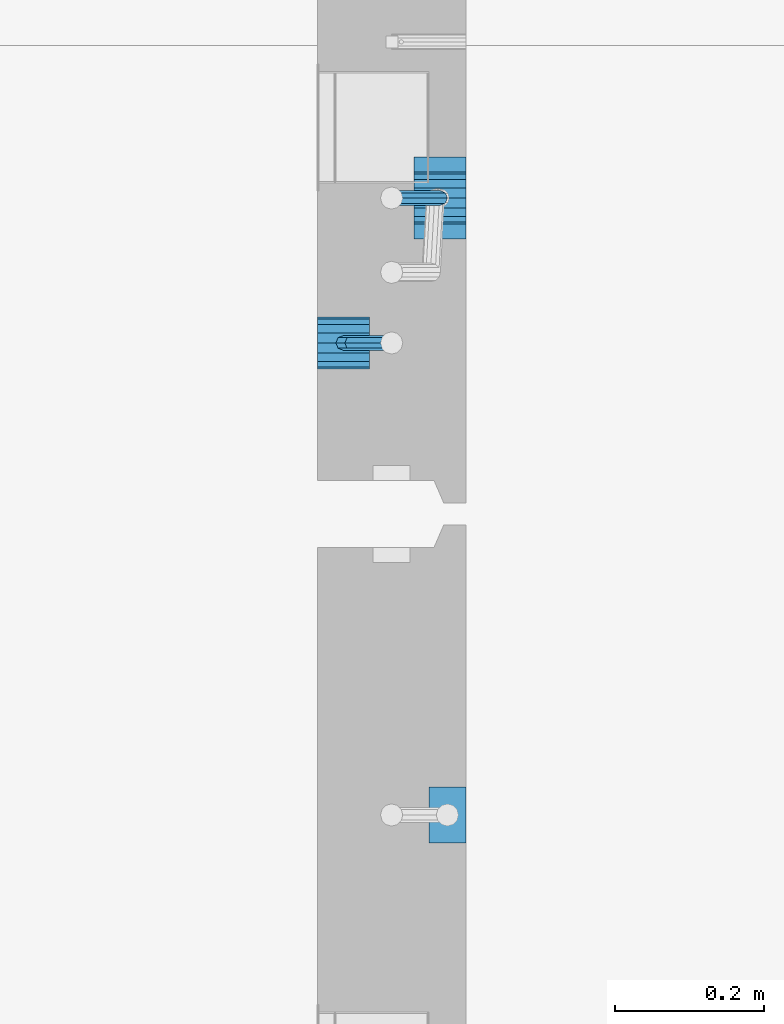
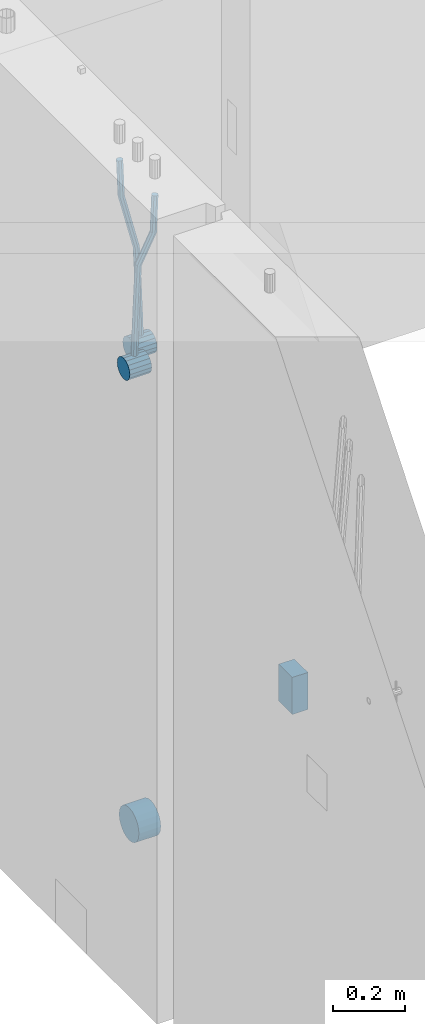
# One storey, part 148 of 349: 6 beams, 2 elements without a shape of their own.
"""IFC2X3 building model written with IfcOpenShell, lengths in millimetres."""

from ifc_helpers import new_model, si_unit, frame, origin_with_axes, place, context, subcontext, project, spatial, faceted_brep, material, type_object, element, aggregate, save


model = new_model("IFC2X3")

# Units and contexts
model_context = context("Model", 3, precision=1e-05, world=origin_with_axes())
body_context = subcontext(model_context, "Body", "Model", "MODEL_VIEW")
ifc_project = project(units=[si_unit("LENGTHUNIT", "METRE", prefix="MILLI"), si_unit("AREAUNIT", "SQUARE_METRE"), si_unit("VOLUMEUNIT", "CUBIC_METRE"), si_unit("MASSUNIT", "GRAM", prefix="KILO"), si_unit("TIMEUNIT", "SECOND"), si_unit("PLANEANGLEUNIT", "RADIAN"), si_unit("SOLIDANGLEUNIT", "STERADIAN"), si_unit("THERMODYNAMICTEMPERATUREUNIT", "DEGREE_CELSIUS"), si_unit("LUMINOUSINTENSITYUNIT", "LUMEN")], contexts=[model_context])

# Site, building, storey
site_placement = place(None, origin_with_axes())
site = spatial("IfcSite", under=ifc_project, at=site_placement, CompositionType="ELEMENT")
building_placement = place(site_placement, origin_with_axes())
building = spatial("IfcBuilding", under=site, at=building_placement, CompositionType="ELEMENT")
storey_placement = place(building_placement, origin_with_axes())
storey = spatial("IfcBuildingStorey", under=building, at=storey_placement, Name="4", CompositionType="ELEMENT", Elevation=0.0)

# Assembly, beams
assembly_1_placement = place(storey_placement, origin_with_axes())
assembly_1 = element("IfcElementAssembly", 1, at=assembly_1_placement, inside=storey, AssemblyPlace="NOTDEFINED", PredefinedType="REINFORCEMENT_UNIT")
ifc_material = material()
beam_type_1 = type_object("IfcBeamType", Name="D20", PredefinedType="NOTDEFINED")
beam_1_placement = place(assembly_1_placement, frame((21875.0000022791, 12925.0000000039, 92795.0), z_axis=(-0.999642804636942, -0.000205726999925762, -0.0267249099902983), x_axis=(-0.0267249099948371, 4.30000201934385e-08, 0.999642825806181)))
beam_1 = element("IfcBeam", 2, at=beam_1_placement, type_object=beam_type_1, material=ifc_material, Name="JM20", ObjectType="D20", context=body_context, shape_type="Brep", body=[
    faceted_brep([(0.0, -10.0, 0.0), (-4.19531716033816e-08, -7.07106781186667, -7.07106781187031), (60.4266690400545, -7.0710677960451, -7.07106780570757), (60.4266690441291, -9.99999998418934, 6.15546014159918e-09), (0.0, 0.0, -10.0), (60.426669036824, 1.58106558956206e-08, -9.99999999384454), (4.196772351861e-08, 7.07106781186303, -7.07106781186667), (60.4266690363438, 7.07106782768096, -7.07106780570757), (0.0, 10.0, 0.0), (60.4266690388904, 10.0000000158179, 6.15182216279209e-09), (4.196772351861e-08, 7.07106781185939, 7.07106781185939), (60.4266690429649, 7.07106782768096, 7.07106781802577), (0.0, 0.0, 10.0), (60.4266690461809, 1.58179318532348e-08, 10.0000000061555), (-4.19531716033816e-08, -7.07106781187031, 7.07106781185939), (60.4266690466611, -7.07106779605238, 7.07106781802213), (61.0378400410118, -7.07106779588503, -7.07106780564936), (60.991799419251, -9.99999998403655, 6.21366780251265e-09), (61.0569027789461, 1.5985278878361e-08, -9.99999999378269), (61.0378209396877, 7.07106782784831, -7.07106780564936), (60.9917724058905, 10.0000000159635, 6.21366780251265e-09), (60.9457317841297, 7.07106782781193, 7.0710678180767), (60.9266690461809, 1.59488990902901e-08, 10.0000000062028), (60.9457508854539, -7.07106779591413, 7.0710678180767), (61.6489592143771, -7.07106614513759, -7.06310863441468), (61.5568818710308, -9.9999984576425, 0.00735959856683621), (61.6870830769039, 1.71821739058942e-06, -9.99179257185824), (61.6489210170112, 7.07106947854481, -7.06310888312146), (61.556827851804, 10.0000015422847, 0.00735924683976918), (61.4647505084577, 7.07106922979438, 7.07782747982128), (61.4266266459163, 1.36643211590126e-06, 10.0065114172685), (61.464788705809, -7.07106639389531, 7.07782772852806), (176.543135720174, -7.07075579406956, -5.56673531796696), (176.451058376813, -9.99968810657447, 1.50373291501455), (176.581259582701, 0.000312069292704109, -8.49541925541052), (176.543097522794, 7.07137982961285, -5.56673556667374), (176.451004357587, 10.00031189336, 1.50373256329476), (176.35892701424, 7.07137958085514, 8.57420079627263), (176.320803151699, 0.000311717507429421, 11.5028847337162), (176.358965211621, -7.07075604281999, 8.57420104497578), (177.098753836006, -7.07075429323595, -5.55949898843028), (176.98362511232, -9.99968666800123, 1.510669025065), (177.146421932586, 0.000313595905026887, -8.48805862247536), (177.098706077581, 7.07138133041735, -5.55949936166144), (176.983557571715, 10.0003133318824, 1.51066849724157), (176.868428848029, 7.07138095712435, 8.58083651073321), (176.820760751449, 0.000313067976094317, 11.5093961447819), (176.868476606425, -7.07075466652896, 8.58083688396073), (177.654312950661, -7.07075204110879, -5.54863964998367), (177.516135294456, -9.99968450931192, 1.52107783331303), (177.711524267797, 0.000315886711177882, -8.47701274570863), (177.654255632195, 7.07138358250813, -5.54864021007961), (177.516054233929, 10.0003154905207, 1.5210770412159), (177.377876577739, 7.0713830223176, 8.59079452451624), (177.320665260588, 0.000315094497636892, 11.5191676202448), (177.377933896176, -7.07075260129932, 8.59079508461218), (298.592214475648, -7.07025824167067, -3.18470470795364), (298.454036904819, -9.99919071054683, 3.88501277673276), (298.649425586758, 0.000809686429420253, -6.11307780703646), (298.592156745173, 7.07187738194261, -3.18470527475802), (298.453955261604, 10.0008092892858, 3.88501197515143), (298.315777690761, 7.07187682041331, 10.9547294598378), (298.258566579665, 0.000808892309578368, 13.883102558917), (298.31583542125, -7.07025880319998, 10.9547300266422), (300.829882012156, -7.07024910539985, -3.14096572775816), (299.972022738802, -9.99918451269514, 3.91468436611831), (301.18507173346, 0.000820039333120803, -6.0635143331092), (300.829526581147, 7.07188651699835, -3.14097211362241), (299.971520083447, 10.0008154854204, 3.91467533514515), (299.113660810108, 7.07188007812692, 10.9703254290253), (298.758471088819, 0.000810933392131119, 13.8928740343799), (299.114016241103, -7.07025554427128, 10.9703318148859), (303.012825988379, -7.0701468967527, -2.64717965084128), (301.452885279024, -9.99911517653163, 4.24965828764471), (303.65870706641, 0.000935858577577164, -5.50397331873319), (303.012180137302, 7.07198871204673, -2.64725173027909), (301.451971907663, 10.0008848023517, 4.24955635192964), (299.892031198324, 7.07191652257279, 11.1463942904193), (299.246150120278, 0.000833767242511385, 14.0031879583075), (299.892677049385, -7.07021908622846, 11.1464663698534), (490.480206458145, -7.06136939830685, 39.7582981627347), (488.920265748791, -9.9903376780876, 46.6551361012243), (491.126087536177, 0.00971335702342913, 36.9015044948464), (490.479560607055, 7.0807662104944, 39.7582260832969), (488.91935237743, 10.0096623007976, 46.6550341655056), (487.359411668076, 7.08069402101864, 53.5518721039953), (486.713530590045, 0.00961126568654436, 56.4086657718872), (487.360057519167, -7.06144158778261, 53.5519441834331), (491.222094319732, -7.06133466202664, 39.9261146072568), (490.367102775039, -9.9902699350514, 46.9824133868096), (491.613766567636, 0.0097361908719904, 37.0118184187741), (491.312683227967, 7.08080521851844, 39.9466800038063), (490.495214837676, 10.0097360849959, 47.0114972495248), (489.640223292983, 7.08080081197113, 54.0677960290814), (489.248551045079, 0.00972995907250152, 56.9820922175604), (489.549634384748, -7.06133906857212, 54.0472306325282), (491.98259360576, -7.07125184727738, 39.9362361015701), (491.850235984879, -10.009610527557, 47.0021524248696), (492.113679795017, 0.00321714190249622, 37.0184717700395), (492.166706040836, 7.06966845271199, 39.958046203883), (492.110610287549, 9.988670745126, 47.0329965673554), (491.978252666668, 7.05031206484455, 54.0989128906476), (491.847166477397, -0.0241569243353297, 57.0166772221819), (491.794140231592, -7.09060823514483, 54.077102788342), (512.839684553823, -7.34323584322192, 40.2138233804726), (512.707326932941, -10.2815945235034, 47.2797397037684), (512.970770743079, -0.268766854042042, 37.296059048942), (513.023796988884, 6.79768445676746, 40.2356334827819), (512.967701235597, 9.71668674918146, 47.3105838462543), (512.83534361473, 6.77832806890183, 54.3765001695538), (512.704257425459, -0.296140920279868, 57.2942645010808), (512.651231179654, -7.36259223108937, 54.3546900672372), (513.475042066755, -7.35152113457298, 40.2222793613946), (513.367413171509, -10.2902022863618, 47.2885247996019), (513.548971693657, -0.276306803183616, 37.3037543324754), (513.545895079456, 6.79087610917486, 40.2425820926655), (513.467614462992, 9.71016770021379, 47.3172371975234), (513.359985567746, 6.77148654842495, 54.3834826357306), (513.286055940844, -0.303727782968053, 57.3020076646499), (513.289132555044, -7.37091069532653, 54.3631799044524), (514.110453382629, -7.34964673829199, 40.2305416874733), (514.027555144421, -10.2882337755309, 47.2971163788461), (514.127221878356, -0.274611275939606, 37.3112548247955), (514.06803787424, 6.7924127919523, 40.249334442502), (513.967570557215, 9.71165861202826, 47.3236933478729), (513.884672319007, 6.77307157479117, 54.3902680392421), (513.867903823266, -0.301963887563034, 57.3095549019235), (513.927087827382, -7.36898795545494, 54.3714752842207), (614.131240716772, -7.05138387012084, 41.5279197320488), (614.048342478563, -9.98997090735793, 48.5944944234179), (614.148009212484, 0.0236515922315448, 38.6086328693636), (614.088825208368, 7.09067566012527, 41.5467124870702), (613.988357891343, 10.0099214802012, 48.6210713924484), (613.905459653135, 7.07133444296232, 55.6876460838175), (613.888691157408, -0.00370101939006418, 58.606932946499), (613.947875161524, -7.07072508728379, 55.6688533287888)], [[[0, 1, 2, 3]], [[1, 4, 5, 2]], [[4, 6, 7, 5]], [[6, 8, 9, 7]], [[8, 10, 11, 9]], [[10, 12, 13, 11]], [[12, 14, 15, 13]], [[14, 0, 3, 15]], [[14, 12, 10, 8, 6, 4, 1, 0]], [[3, 2, 16, 17]], [[2, 5, 18, 16]], [[5, 7, 19, 18]], [[7, 9, 20, 19]], [[9, 11, 21, 20]], [[11, 13, 22, 21]], [[13, 15, 23, 22]], [[15, 3, 17, 23]], [[17, 16, 24, 25]], [[16, 18, 26, 24]], [[18, 19, 27, 26]], [[19, 20, 28, 27]], [[20, 21, 29, 28]], [[21, 22, 30, 29]], [[22, 23, 31, 30]], [[23, 17, 25, 31]], [[25, 24, 32, 33]], [[24, 26, 34, 32]], [[26, 27, 35, 34]], [[27, 28, 36, 35]], [[28, 29, 37, 36]], [[29, 30, 38, 37]], [[30, 31, 39, 38]], [[31, 25, 33, 39]], [[33, 32, 40, 41]], [[32, 34, 42, 40]], [[34, 35, 43, 42]], [[35, 36, 44, 43]], [[36, 37, 45, 44]], [[37, 38, 46, 45]], [[38, 39, 47, 46]], [[39, 33, 41, 47]], [[41, 40, 48, 49]], [[40, 42, 50, 48]], [[42, 43, 51, 50]], [[43, 44, 52, 51]], [[44, 45, 53, 52]], [[45, 46, 54, 53]], [[46, 47, 55, 54]], [[47, 41, 49, 55]], [[49, 48, 56, 57]], [[48, 50, 58, 56]], [[50, 51, 59, 58]], [[51, 52, 60, 59]], [[52, 53, 61, 60]], [[53, 54, 62, 61]], [[54, 55, 63, 62]], [[55, 49, 57, 63]], [[57, 56, 64, 65]], [[56, 58, 66, 64]], [[58, 59, 67, 66]], [[59, 60, 68, 67]], [[60, 61, 69, 68]], [[61, 62, 70, 69]], [[62, 63, 71, 70]], [[63, 57, 65, 71]], [[65, 64, 72, 73]], [[64, 66, 74, 72]], [[66, 67, 75, 74]], [[67, 68, 76, 75]], [[68, 69, 77, 76]], [[69, 70, 78, 77]], [[70, 71, 79, 78]], [[71, 65, 73, 79]], [[73, 72, 80, 81]], [[72, 74, 82, 80]], [[74, 75, 83, 82]], [[75, 76, 84, 83]], [[76, 77, 85, 84]], [[77, 78, 86, 85]], [[78, 79, 87, 86]], [[79, 73, 81, 87]], [[81, 80, 88, 89]], [[80, 82, 90, 88]], [[82, 83, 91, 90]], [[83, 84, 92, 91]], [[84, 85, 93, 92]], [[85, 86, 94, 93]], [[86, 87, 95, 94]], [[87, 81, 89, 95]], [[89, 88, 96, 97]], [[88, 90, 98, 96]], [[90, 91, 99, 98]], [[91, 92, 100, 99]], [[92, 93, 101, 100]], [[93, 94, 102, 101]], [[94, 95, 103, 102]], [[95, 89, 97, 103]], [[97, 96, 104, 105]], [[96, 98, 106, 104]], [[98, 99, 107, 106]], [[99, 100, 108, 107]], [[100, 101, 109, 108]], [[101, 102, 110, 109]], [[102, 103, 111, 110]], [[103, 97, 105, 111]], [[105, 104, 112, 113]], [[104, 106, 114, 112]], [[106, 107, 115, 114]], [[107, 108, 116, 115]], [[108, 109, 117, 116]], [[109, 110, 118, 117]], [[110, 111, 119, 118]], [[111, 105, 113, 119]], [[113, 112, 120, 121]], [[112, 114, 122, 120]], [[114, 115, 123, 122]], [[115, 116, 124, 123]], [[116, 117, 125, 124]], [[117, 118, 126, 125]], [[118, 119, 127, 126]], [[119, 113, 121, 127]], [[121, 120, 128, 129]], [[120, 122, 130, 128]], [[122, 123, 131, 130]], [[123, 124, 132, 131]], [[124, 125, 133, 132]], [[125, 126, 134, 133]], [[126, 127, 135, 134]], [[127, 121, 129, 135]], [[130, 131, 132, 133, 134, 135, 129, 128]]]),
])
beam_2_placement = place(assembly_1_placement, frame((21744.9999977209, 12729.9999999961, 92890.0), z_axis=(0.999642804629538, 0.000205762999925497, -0.0267249099901003), x_axis=(0.0267249109941254, -4.30000210532798e-08, 0.999642825779465)))
beam_2 = element("IfcBeam", 3, at=beam_2_placement, type_object=beam_type_1, material=ifc_material, Name="JM20", ObjectType="D20", context=body_context, shape_type="Brep", body=[
    faceted_brep([(0.0, -10.0, 0.0), (-4.19531716033816e-08, -7.07106781186667, -7.07106781187031), (60.4266690400545, -7.0710677960451, -7.07106780570757), (60.4266690441291, -9.99999998418934, 6.15546014159918e-09), (0.0, 0.0, -10.0), (60.426669036824, 1.58106558956206e-08, -9.99999999384454), (4.196772351861e-08, 7.07106781186303, -7.07106781186667), (60.4266690363438, 7.07106782768096, -7.07106780570757), (0.0, 10.0, 0.0), (60.4266690388904, 10.0000000158179, 6.15182216279209e-09), (4.196772351861e-08, 7.07106781185939, 7.07106781185939), (60.4266690429649, 7.07106782768096, 7.07106781802577), (0.0, 0.0, 10.0), (60.4266690461809, 1.58179318532348e-08, 10.0000000061555), (-4.19531716033816e-08, -7.07106781187031, 7.07106781185939), (60.4266690466611, -7.07106779605238, 7.07106781802213), (61.0378400410118, -7.07106779588503, -7.07106780564936), (60.991799419251, -9.99999998403655, 6.21366780251265e-09), (61.0569027789461, 1.5985278878361e-08, -9.99999999378269), (61.0378209396877, 7.07106782784831, -7.07106780564936), (60.9917724058905, 10.0000000159635, 6.21366780251265e-09), (60.9457317841297, 7.07106782781193, 7.0710678180767), (60.9266690461809, 1.59488990902901e-08, 10.0000000062028), (60.9457508854539, -7.07106779591413, 7.0710678180767), (61.6489592143771, -7.07106614513759, -7.06310863441468), (61.5568818710308, -9.9999984576425, 0.00735959856683621), (61.6870830769039, 1.71821739058942e-06, -9.99179257185824), (61.6489210170112, 7.07106947854481, -7.06310888312146), (61.556827851804, 10.0000015422847, 0.00735924683976918), (61.4647505084577, 7.07106922979438, 7.07782747982128), (61.4266266459163, 1.36643211590126e-06, 10.0065114172685), (61.464788705809, -7.07106639389531, 7.07782772852806), (176.543135720174, -7.07075579406956, -5.56673531796696), (176.451058376813, -9.99968810657447, 1.50373291501455), (176.581259582701, 0.000312069292704109, -8.49541925541052), (176.543097522794, 7.07137982961285, -5.56673556667374), (176.451004357587, 10.00031189336, 1.50373256329476), (176.35892701424, 7.07137958085514, 8.57420079627263), (176.320803151699, 0.000311717507429421, 11.5028847337162), (176.358965211621, -7.07075604281999, 8.57420104497578), (177.098753836006, -7.07075429323595, -5.55949898843028), (176.98362511232, -9.99968666800123, 1.510669025065), (177.146421932586, 0.000313595905026887, -8.48805862247536), (177.098706077581, 7.07138133041735, -5.55949936166144), (176.983557571715, 10.0003133318824, 1.51066849724157), (176.868428848029, 7.07138095712435, 8.58083651073321), (176.820760751449, 0.000313067976094317, 11.5093961447819), (176.868476606425, -7.07075466652896, 8.58083688396073), (177.654312950661, -7.07075204110879, -5.54863964998367), (177.516135294456, -9.99968450931192, 1.52107783331303), (177.711524267797, 0.000315886711177882, -8.47701274570863), (177.654255632195, 7.07138358250813, -5.54864021007961), (177.516054233929, 10.0003154905207, 1.5210770412159), (177.377876577739, 7.0713830223176, 8.59079452451624), (177.320665260588, 0.000315094497636892, 11.5191676202448), (177.377933896176, -7.07075260129932, 8.59079508461218), (297.446964549832, -7.07026642590426, -3.20709054437975), (297.308786893627, -9.99919889410376, 3.86262693891331), (297.504175866998, 0.000801501919340808, -6.13546364010836), (297.44690723141, 7.07186919770902, -3.20709110447569), (297.308705833115, 10.0008011057289, 3.86262614682164), (297.170528176895, 7.07186863752577, 10.9323436301165), (297.113316859759, 0.000800709702161839, 13.8607167258415), (297.170585495318, -7.07026698608752, 10.9323441902106), (301.63986343499, -7.07024942873613, -3.12513327486886), (299.972259732356, -9.99918809692099, 3.91468900081236), (302.330321453323, 0.000821066147182137, -6.04112849743797), (301.639172844472, 7.07188619231601, -3.12514621333321), (299.971283089879, 10.0008118992846, 3.91467070306135), (298.303679387245, 7.07187323109611, 10.9544929787371), (297.613221368898, 0.000802736216428457, 13.870488201308), (298.304369977734, -7.0702623899524, 10.9545059172033), (305.4239078393, -7.06987516590743, -1.31733741553398), (302.376014215231, -9.99895035236841, 5.06306278734701), (306.685863931343, 0.00125185327851796, -3.96030416885333), (305.422645727784, 7.07226039861052, -1.31762339341367), (302.374229320019, 10.0010495638962, 5.06265835355225), (299.326335695951, 7.07197437743162, 11.4430585564332), (298.064379603893, 0.000847358245664509, 14.0860253097508), (299.327597807453, -7.07016118708634, 11.4433445343111), (396.081143409523, -7.0609086662007, 41.9934056867296), (393.033249785469, -9.98998385266168, 48.3738058896106), (397.34309950161, 0.0102183529888862, 39.3504389334103), (396.079881298036, 7.08122689832453, 41.9931197088481), (393.031464890271, 10.0100160636066, 48.3734014558122), (389.983571266188, 7.08094087714562, 54.753801658695), (388.72161517413, 0.00981385795967071, 57.3967684120162), (389.984833377704, -7.06119468737961, 54.7540876365765), (397.068790959223, -7.06081098241702, 42.4652461198857), (395.403898118791, -9.98974938248648, 49.5063634875187), (397.79425773659, 0.0102629750217602, 39.565976041853), (397.155329851754, 7.08133326610914, 42.5069063441551), (395.526282594277, 10.0102628148125, 49.5652799416912), (393.861389753831, 7.08132441474299, 56.606397309326), (393.135922976478, 0.0102504573078477, 59.5056673873569), (393.774850861315, -7.06081983378317, 56.5647370850584), (398.163169908337, -7.0750819080713, 42.4798112226927), (398.030733605352, -10.0240038552729, 49.541324073105), (398.294170965004, 0.00374400413056719, 39.572629393122), (398.346998133013, 7.06579366763617, 42.5227662718698), (398.290705973835, 9.97421416771613, 49.6020716862276), (398.15826967085, 7.02529222051089, 56.6635845366436), (398.027268614198, -0.0535336916836968, 59.5707663662142), (397.974441446175, -7.11558335519294, 56.6206294874646), (417.87389934808, -7.33211385723553, 42.7421415616409), (417.741463045095, -10.2810358044335, 49.803654412055), (418.004900404732, -0.253287945030024, 39.8349597320685), (418.057727572756, 6.8087617184683, 42.7850966108181), (418.001435413564, 9.71718221855917, 49.8644020251777), (417.868999110593, 6.76826027135394, 56.92591487559), (417.737998053926, -0.310565640847926, 59.8330967051625), (417.685170885918, -7.37261530435353, 56.8829598264128), (418.509166047603, -7.3403978651113, 42.7505963339045), (418.401542092906, -10.2896433704191, 49.812439412166), (418.582978010687, -0.260826195415575, 39.8426533739894), (418.579739935274, 6.80195457034279, 42.7920440797316), (418.501348641992, 9.71066324766434, 49.8710553764413), (418.393724687281, 6.76141774235657, 56.9328984547028), (418.319912724211, -0.318153927339154, 59.8408414146197), (418.323150799639, -7.38093469310479, 56.8914507088775), (419.144486528079, -7.33852513420788, 42.7588588031304), (419.061676848418, -10.2876749343814, 49.821032815089), (419.161104845465, -0.25913295731516, 39.8501522177412), (419.101797015624, 6.80348967242753, 42.7987939276718), (419.00130476091, 9.71215420445515, 49.8775096098252), (418.918495081249, 6.76300440428531, 56.9396836217802), (418.901876763863, -0.316387772607413, 59.8483902071712), (418.961184593718, -7.37901040236102, 56.8997484972406), (519.165277458538, -7.04026297675227, 44.0562368946885), (519.082467778877, -9.98941277692575, 51.1184109066417), (519.181895775939, 0.0391292001404508, 41.1475303092957), (519.122587946098, 7.10175182989406, 44.0961720192245), (519.022095691384, 10.0104163619108, 51.1748877013797), (518.939286011722, 7.06126656174456, 58.2370617133347), (518.922667694336, -0.0181256151481648, 61.1457682987275), (518.981975524162, -7.08074824490541, 58.1971265887951)], [[[0, 1, 2, 3]], [[1, 4, 5, 2]], [[4, 6, 7, 5]], [[6, 8, 9, 7]], [[8, 10, 11, 9]], [[10, 12, 13, 11]], [[12, 14, 15, 13]], [[14, 0, 3, 15]], [[14, 12, 10, 8, 6, 4, 1, 0]], [[3, 2, 16, 17]], [[2, 5, 18, 16]], [[5, 7, 19, 18]], [[7, 9, 20, 19]], [[9, 11, 21, 20]], [[11, 13, 22, 21]], [[13, 15, 23, 22]], [[15, 3, 17, 23]], [[17, 16, 24, 25]], [[16, 18, 26, 24]], [[18, 19, 27, 26]], [[19, 20, 28, 27]], [[20, 21, 29, 28]], [[21, 22, 30, 29]], [[22, 23, 31, 30]], [[23, 17, 25, 31]], [[25, 24, 32, 33]], [[24, 26, 34, 32]], [[26, 27, 35, 34]], [[27, 28, 36, 35]], [[28, 29, 37, 36]], [[29, 30, 38, 37]], [[30, 31, 39, 38]], [[31, 25, 33, 39]], [[33, 32, 40, 41]], [[32, 34, 42, 40]], [[34, 35, 43, 42]], [[35, 36, 44, 43]], [[36, 37, 45, 44]], [[37, 38, 46, 45]], [[38, 39, 47, 46]], [[39, 33, 41, 47]], [[41, 40, 48, 49]], [[40, 42, 50, 48]], [[42, 43, 51, 50]], [[43, 44, 52, 51]], [[44, 45, 53, 52]], [[45, 46, 54, 53]], [[46, 47, 55, 54]], [[47, 41, 49, 55]], [[49, 48, 56, 57]], [[48, 50, 58, 56]], [[50, 51, 59, 58]], [[51, 52, 60, 59]], [[52, 53, 61, 60]], [[53, 54, 62, 61]], [[54, 55, 63, 62]], [[55, 49, 57, 63]], [[57, 56, 64, 65]], [[56, 58, 66, 64]], [[58, 59, 67, 66]], [[59, 60, 68, 67]], [[60, 61, 69, 68]], [[61, 62, 70, 69]], [[62, 63, 71, 70]], [[63, 57, 65, 71]], [[65, 64, 72, 73]], [[64, 66, 74, 72]], [[66, 67, 75, 74]], [[67, 68, 76, 75]], [[68, 69, 77, 76]], [[69, 70, 78, 77]], [[70, 71, 79, 78]], [[71, 65, 73, 79]], [[73, 72, 80, 81]], [[72, 74, 82, 80]], [[74, 75, 83, 82]], [[75, 76, 84, 83]], [[76, 77, 85, 84]], [[77, 78, 86, 85]], [[78, 79, 87, 86]], [[79, 73, 81, 87]], [[81, 80, 88, 89]], [[80, 82, 90, 88]], [[82, 83, 91, 90]], [[83, 84, 92, 91]], [[84, 85, 93, 92]], [[85, 86, 94, 93]], [[86, 87, 95, 94]], [[87, 81, 89, 95]], [[89, 88, 96, 97]], [[88, 90, 98, 96]], [[90, 91, 99, 98]], [[91, 92, 100, 99]], [[92, 93, 101, 100]], [[93, 94, 102, 101]], [[94, 95, 103, 102]], [[95, 89, 97, 103]], [[97, 96, 104, 105]], [[96, 98, 106, 104]], [[98, 99, 107, 106]], [[99, 100, 108, 107]], [[100, 101, 109, 108]], [[101, 102, 110, 109]], [[102, 103, 111, 110]], [[103, 97, 105, 111]], [[105, 104, 112, 113]], [[104, 106, 114, 112]], [[106, 107, 115, 114]], [[107, 108, 116, 115]], [[108, 109, 117, 116]], [[109, 110, 118, 117]], [[110, 111, 119, 118]], [[111, 105, 113, 119]], [[113, 112, 120, 121]], [[112, 114, 122, 120]], [[114, 115, 123, 122]], [[115, 116, 124, 123]], [[116, 117, 125, 124]], [[117, 118, 126, 125]], [[118, 119, 127, 126]], [[119, 113, 121, 127]], [[121, 120, 128, 129]], [[120, 122, 130, 128]], [[122, 123, 131, 130]], [[123, 124, 132, 131]], [[124, 125, 133, 132]], [[125, 126, 134, 133]], [[126, 127, 135, 134]], [[127, 121, 129, 135]], [[130, 131, 132, 133, 134, 135, 129, 128]]]),
])
beam_type_2 = type_object("IfcBeamType", Name="D70", PredefinedType="NOTDEFINED")
beam_3_placement = place(assembly_1_placement, frame((21839.9999977209, 12925.0, 92760.0), z_axis=(0.0, 0.0, 1.0), x_axis=(1.0, 0.0, 0.0)))
beam_3 = element("IfcBeam", 4, at=beam_3_placement, type_object=beam_type_2, material=ifc_material, ObjectType="D70", context=body_context, shape_type="Brep", body=[
    faceted_brep([(0.0, -35.0, 0.0), (0.0, -32.3357836378964, -13.3939201327739), (70.0, -32.3357836378964, -13.3939201327739), (70.0, -35.0, 0.0), (0.0, -24.7487373415279, -24.7487373415352), (70.0, -24.7487373415279, -24.7487373415352), (0.0, -13.3939201327776, -32.3357836379), (70.0, -13.3939201327776, -32.3357836379), (0.0, 0.0, -35.0), (70.0, 0.0, -35.0), (0.0, 13.3939201327776, -32.3357836379), (70.0, 13.3939201327776, -32.3357836379), (0.0, 24.7487373415279, -24.7487373415352), (70.0, 24.7487373415279, -24.7487373415352), (0.0, 32.3357836378964, -13.3939201327739), (70.0, 32.3357836378964, -13.3939201327739), (0.0, 35.0, 0.0), (70.0, 35.0, 0.0), (0.0, 32.3357836378964, 13.3939201327739), (70.0, 32.3357836378964, 13.3939201327739), (0.0, 24.7487373415279, 24.7487373415352), (70.0, 24.7487373415279, 24.7487373415352), (0.0, 13.3939201327776, 32.3357836379), (70.0, 13.3939201327776, 32.3357836379), (0.0, 0.0, 35.0), (70.0, 0.0, 35.0), (0.0, -13.3939201327776, 32.3357836379), (70.0, -13.3939201327776, 32.3357836379), (0.0, -24.7487373415279, 24.7487373415352), (70.0, -24.7487373415279, 24.7487373415352), (0.0, -32.3357836378964, 13.3939201327739), (70.0, -32.3357836378964, 13.3939201327739)], [[[0, 1, 2, 3]], [[1, 4, 5, 2]], [[4, 6, 7, 5]], [[6, 8, 9, 7]], [[8, 10, 11, 9]], [[10, 12, 13, 11]], [[12, 14, 15, 13]], [[14, 16, 17, 15]], [[16, 18, 19, 17]], [[18, 20, 21, 19]], [[20, 22, 23, 21]], [[22, 24, 25, 23]], [[24, 26, 27, 25]], [[26, 28, 29, 27]], [[28, 30, 31, 29]], [[30, 0, 3, 31]], [[5, 7, 9, 11, 13, 15, 17, 19, 21, 23, 25, 27, 29, 31, 3, 2]], [[30, 28, 26, 24, 22, 20, 18, 16, 14, 12, 10, 8, 6, 4, 1, 0]]]),
])
beam_4_placement = place(assembly_1_placement, frame((21709.9999977209, 12730.0, 92855.0), z_axis=(0.0, 0.0, 1.0), x_axis=(1.0, 0.0, 0.0)))
beam_4 = element("IfcBeam", 5, at=beam_4_placement, type_object=beam_type_2, material=ifc_material, ObjectType="D70", context=body_context, shape_type="Brep", body=[
    faceted_brep([(0.0, -35.0, 0.0), (0.0, -32.3357836378964, -13.3939201327739), (70.0, -32.3357836378964, -13.3939201327739), (70.0, -35.0, 0.0), (0.0, -24.7487373415279, -24.7487373415352), (70.0, -24.7487373415279, -24.7487373415352), (0.0, -13.3939201327776, -32.3357836379), (70.0, -13.3939201327776, -32.3357836379), (0.0, 0.0, -35.0), (70.0, 0.0, -35.0), (0.0, 13.3939201327776, -32.3357836379), (70.0, 13.3939201327776, -32.3357836379), (0.0, 24.7487373415279, -24.7487373415352), (70.0, 24.7487373415279, -24.7487373415352), (0.0, 32.3357836378964, -13.3939201327739), (70.0, 32.3357836378964, -13.3939201327739), (0.0, 35.0, 0.0), (70.0, 35.0, 0.0), (0.0, 32.3357836378964, 13.3939201327739), (70.0, 32.3357836378964, 13.3939201327739), (0.0, 24.7487373415279, 24.7487373415352), (70.0, 24.7487373415279, 24.7487373415352), (0.0, 13.3939201327776, 32.3357836379), (70.0, 13.3939201327776, 32.3357836379), (0.0, 0.0, 35.0), (70.0, 0.0, 35.0), (0.0, -13.3939201327776, 32.3357836379), (70.0, -13.3939201327776, 32.3357836379), (0.0, -24.7487373415279, 24.7487373415352), (70.0, -24.7487373415279, 24.7487373415352), (0.0, -32.3357836378964, 13.3939201327739), (70.0, -32.3357836378964, 13.3939201327739)], [[[0, 1, 2, 3]], [[1, 4, 5, 2]], [[4, 6, 7, 5]], [[6, 8, 9, 7]], [[8, 10, 11, 9]], [[10, 12, 13, 11]], [[12, 14, 15, 13]], [[14, 16, 17, 15]], [[16, 18, 19, 17]], [[18, 20, 21, 19]], [[20, 22, 23, 21]], [[22, 24, 25, 23]], [[24, 26, 27, 25]], [[26, 28, 29, 27]], [[28, 30, 31, 29]], [[30, 0, 3, 31]], [[5, 7, 9, 11, 13, 15, 17, 19, 21, 23, 25, 27, 29, 31, 3, 2]], [[30, 28, 26, 24, 22, 20, 18, 16, 14, 12, 10, 8, 6, 4, 1, 0]]]),
])
beam_type_3 = type_object("IfcBeamType", Name="D110", PredefinedType="NOTDEFINED")
beam_5_placement = place(assembly_1_placement, frame((21910.0000022791, 12925.0, 91155.0), z_axis=(0.0, 0.0, 1.0), x_axis=(-1.0, 3.00000001838171e-08, 0.0)))
beam_5 = element("IfcBeam", 6, at=beam_5_placement, type_object=beam_type_3, material=ifc_material, ObjectType="D110", context=body_context, shape_type="Brep", body=[
    faceted_brep([(0.0, -55.0, 0.0), (0.0, -52.3081083962352, -16.9959346906253), (70.0, -52.3081083962352, -16.9959346906253), (70.0, -55.0, 0.0), (0.0, -44.4959346906217, -32.328188876083), (70.0, -44.4959346906217, -32.328188876083), (0.0, -32.3281888760866, -44.4959346906253), (70.0, -32.3281888760866, -44.4959346906253), (0.0, -16.9959346906217, -52.3081083962315), (70.0, -16.9959346906217, -52.3081083962315), (0.0, 0.0, -55.0), (70.0, 0.0, -55.0), (0.0, 16.9959346906217, -52.3081083962315), (70.0, 16.9959346906217, -52.3081083962315), (0.0, 32.3281888760866, -44.4959346906253), (70.0, 32.3281888760866, -44.4959346906253), (0.0, 44.4959346906217, -32.328188876083), (70.0, 44.4959346906217, -32.328188876083), (0.0, 52.3081083962352, -16.9959346906253), (70.0, 52.3081083962352, -16.9959346906253), (0.0, 55.0, 0.0), (70.0, 55.0, 0.0), (0.0, 52.3081083962352, 16.9959346906253), (70.0, 52.3081083962352, 16.9959346906253), (0.0, 44.4959346906217, 32.328188876083), (70.0, 44.4959346906217, 32.328188876083), (0.0, 32.3281888760866, 44.4959346906253), (70.0, 32.3281888760866, 44.4959346906253), (0.0, 16.9959346906217, 52.3081083962315), (70.0, 16.9959346906217, 52.3081083962315), (0.0, 0.0, 55.0), (70.0, 0.0, 55.0), (0.0, -16.9959346906217, 52.3081083962315), (70.0, -16.9959346906217, 52.3081083962315), (0.0, -32.3281888760866, 44.4959346906253), (70.0, -32.3281888760866, 44.4959346906253), (0.0, -44.4959346906217, 32.328188876083), (70.0, -44.4959346906217, 32.328188876083), (0.0, -52.3081083962352, 16.9959346906253), (70.0, -52.3081083962352, 16.9959346906253)], [[[0, 1, 2, 3]], [[1, 4, 5, 2]], [[4, 6, 7, 5]], [[6, 8, 9, 7]], [[8, 10, 11, 9]], [[10, 12, 13, 11]], [[12, 14, 15, 13]], [[14, 16, 17, 15]], [[16, 18, 19, 17]], [[18, 20, 21, 19]], [[20, 22, 23, 21]], [[22, 24, 25, 23]], [[24, 26, 27, 25]], [[26, 28, 29, 27]], [[28, 30, 31, 29]], [[30, 32, 33, 31]], [[32, 34, 35, 33]], [[34, 36, 37, 35]], [[36, 38, 39, 37]], [[38, 0, 3, 39]], [[5, 7, 9, 11, 13, 15, 17, 19, 21, 23, 25, 27, 29, 31, 33, 35, 37, 39, 3, 2]], [[38, 36, 34, 32, 30, 28, 26, 24, 22, 20, 18, 16, 14, 12, 10, 8, 6, 4, 1, 0]]]),
])
aggregate(assembly_1, [beam_1, beam_3, beam_2, beam_4, beam_5])

# Assembly, beam
assembly_2_placement = place(storey_placement, origin_with_axes())
assembly_2 = element("IfcElementAssembly", 7, at=assembly_2_placement, inside=storey, AssemblyPlace="NOTDEFINED", PredefinedType="REINFORCEMENT_UNIT")
beam_type_4 = type_object("IfcBeamType", Name="125X50", PredefinedType="NOTDEFINED")
beam_6_placement = place(assembly_2_placement, frame((21885.0, 12057.5, 92105.0), z_axis=(0.0, 0.0, 1.0), x_axis=(0.0, 1.0, 0.0)))
beam_6 = element("IfcBeam", 8, at=beam_6_placement, type_object=beam_type_4, material=ifc_material, Name="WM1", ObjectType="125X50", context=body_context, shape_type="Brep", body=[
    faceted_brep([(0.0, 25.0, -62.5), (0.0, 25.0, 62.5), (75.0, 25.0, 62.5), (75.0, 25.0, -62.5), (0.0, -25.0, 62.5), (75.0, -25.0, 62.5), (0.0, -25.0, -62.5), (75.0, -25.0, -62.5)], [[[0, 1, 2, 3]], [[1, 4, 5, 2]], [[4, 6, 7, 5]], [[6, 0, 3, 7]], [[5, 7, 3, 2]], [[0, 6, 4, 1]]]),
])
aggregate(assembly_2, [beam_6])

save(model, "model.ifc")
